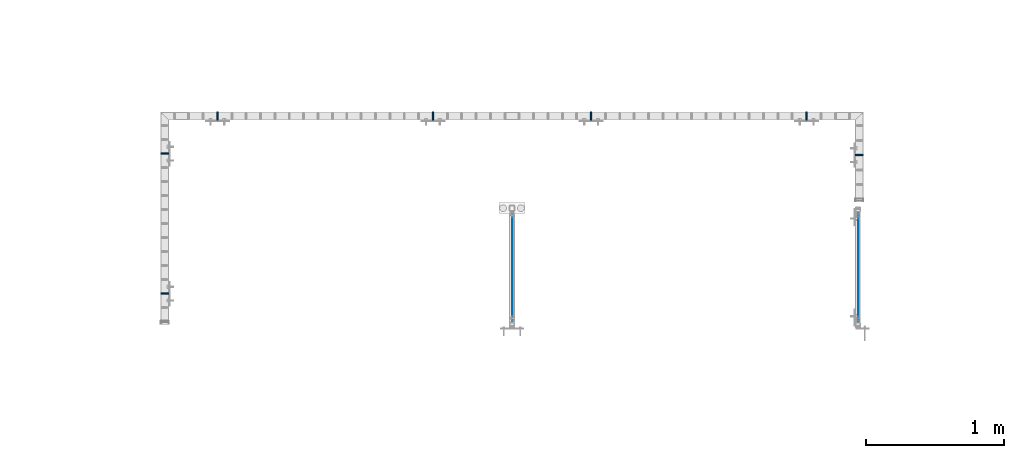
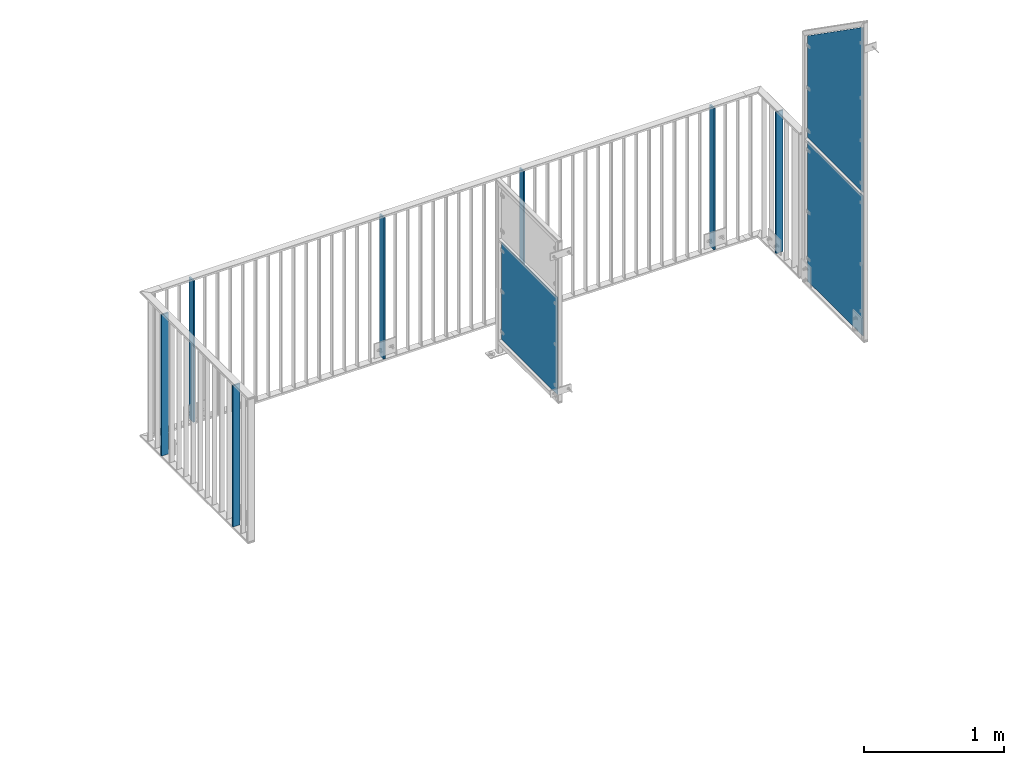
# One storey, part 48 of 156: 10 plates, 7 elements without a shape of their own.
"""IFC2X3 building model written with IfcOpenShell, lengths in millimetres."""

from ifc_helpers import new_model, si_unit, frame, origin_with_axes, origin_2d_with_axis, place, context, subcontext, project, spatial, rectangle, extrude, clip, halfspace, material, type_object, element, aggregate, save


model = new_model("IFC2X3")

# Units and contexts
model_context = context("Model", 3, precision=1e-05, world=origin_with_axes())
body_context = subcontext(model_context, "Body", "Model", "MODEL_VIEW")
ifc_project = project(units=[si_unit("LENGTHUNIT", "METRE", prefix="MILLI"), si_unit("AREAUNIT", "SQUARE_METRE"), si_unit("VOLUMEUNIT", "CUBIC_METRE"), si_unit("MASSUNIT", "GRAM", prefix="KILO"), si_unit("TIMEUNIT", "SECOND"), si_unit("PLANEANGLEUNIT", "RADIAN"), si_unit("SOLIDANGLEUNIT", "STERADIAN"), si_unit("THERMODYNAMICTEMPERATUREUNIT", "DEGREE_CELSIUS"), si_unit("LUMINOUSINTENSITYUNIT", "LUMEN")], contexts=[model_context])

# Site, building, storey
site_placement = place(None, origin_with_axes())
site = spatial("IfcSite", under=ifc_project, at=site_placement, CompositionType="ELEMENT")
building_placement = place(site_placement, origin_with_axes())
building = spatial("IfcBuilding", under=site, at=building_placement, Name="Undefined", CompositionType="ELEMENT")
storey_placement = place(building_placement, origin_with_axes())
storey = spatial("IfcBuildingStorey", under=building, at=storey_placement, Name="Undefined", CompositionType="ELEMENT", Elevation=0.0)

# Assembly, plate
assembly_1_placement = place(storey_placement, origin_with_axes())
assembly_1 = element("IfcElementAssembly", 1, at=assembly_1_placement, inside=storey, AssemblyPlace="NOTDEFINED", PredefinedType="RIGID_FRAME")
ifc_material = material(Name="STEEL/S235JR")
plate_type_1 = type_object("IfcPlateType", PredefinedType="NOTDEFINED")
plate_1_placement = place(assembly_1_placement, frame((41074.9973674284, 20366.5798484974, 3980.00000000003), z_axis=(1.0, 0.0, 0.0), x_axis=(0.0, 0.0, -1.0)))
plate_1 = element("IfcPlate", 2, at=plate_1_placement, type_object=plate_type_1, material=ifc_material, context=body_context, shape_type="SweptSolid", body=[
    extrude(rectangle(XDim=12.0, YDim=60.0, at=origin_2d_with_axis()), frame((1230.0, 0.0, 0.0), z_axis=(-1.0, 0.0, 0.0), x_axis=(0.0, -1.0, 0.0)), (0.0, 0.0, 1.0), 1230.0),
])

assembly_2_placement = place(storey_placement, origin_with_axes())
assembly_2 = element("IfcElementAssembly", 3, at=assembly_2_placement, inside=storey, AssemblyPlace="NOTDEFINED", PredefinedType="RIGID_FRAME")
plate_2_placement = place(assembly_2_placement, frame((44174.6444496975, 21657.9904407992, 3980.00000000003), z_axis=(0.0, -1.0, 0.0), x_axis=(0.0, 0.0, -1.0)))
plate_2 = element("IfcPlate", 4, at=plate_2_placement, type_object=plate_type_1, material=ifc_material, context=body_context, shape_type="SweptSolid", body=[
    extrude(rectangle(XDim=12.0, YDim=60.0, at=origin_2d_with_axis()), frame((1230.0, 0.0, 0.0), z_axis=(-1.0, 0.0, 0.0), x_axis=(0.0, -1.0, 0.0)), (0.0, 0.0, 1.0), 1230.0),
])

# Assembly, plates
assembly_3_placement = place(storey_placement, origin_with_axes())
assembly_3 = element("IfcElementAssembly", 5, at=assembly_3_placement, inside=storey, AssemblyPlace="NOTDEFINED", PredefinedType="RIGID_FRAME")
plate_3_placement = place(assembly_3_placement, frame((43025.3391913759, 21657.9904407992, 3980.00000000003), z_axis=(0.0, -1.0, 0.0), x_axis=(0.0, 0.0, -1.0)))
plate_3 = element("IfcPlate", 6, at=plate_3_placement, type_object=plate_type_1, material=ifc_material, context=body_context, shape_type="SweptSolid", body=[
    extrude(rectangle(XDim=12.0, YDim=60.0, at=origin_2d_with_axis()), frame((1230.0, 0.0, 0.0), z_axis=(-1.0, 0.0, 0.0), x_axis=(0.0, -1.0, 0.0)), (0.0, 0.0, 1.0), 1230.0),
])
plate_4_placement = place(assembly_3_placement, frame((41458.3177394665, 21657.9904407992, 3980.00000000003), z_axis=(0.0, -1.0, 0.0), x_axis=(0.0, 0.0, -1.0)))
plate_4 = element("IfcPlate", 7, at=plate_4_placement, type_object=plate_type_1, material=ifc_material, context=body_context, shape_type="SweptSolid", body=[
    extrude(rectangle(XDim=12.0, YDim=60.0, at=origin_2d_with_axis()), frame((1230.0, 0.0, 0.0), z_axis=(-1.0, 0.0, 0.0), x_axis=(0.0, -1.0, 0.0)), (0.0, 0.0, 1.0), 1230.0),
])
aggregate(assembly_3, [plate_3, plate_4])

# Assembly, plate
assembly_4_placement = place(storey_placement, origin_with_axes())
assembly_4 = element("IfcElementAssembly", 8, at=assembly_4_placement, inside=storey, AssemblyPlace="NOTDEFINED", PredefinedType="RIGID_FRAME")
plate_5_placement = place(assembly_4_placement, frame((46124.9972919954, 21374.1492182574, 3980.00000000003), z_axis=(-1.0, 0.0, 0.0), x_axis=(0.0, 0.0, -1.0)))
plate_5 = element("IfcPlate", 9, at=plate_5_placement, type_object=plate_type_1, material=ifc_material, context=body_context, shape_type="SweptSolid", body=[
    extrude(rectangle(XDim=12.0, YDim=60.0, at=origin_2d_with_axis()), frame((1230.0, 0.0, 0.0), z_axis=(-1.0, 0.0, 0.0), x_axis=(0.0, -1.0, 0.0)), (0.0, 0.0, 1.0), 1230.0),
])
aggregate(assembly_4, [plate_5])

# Plate
plate_6_placement = place(assembly_2_placement, frame((45741.665901607, 21657.9904407992, 3980.00000000003), z_axis=(0.0, -1.0, 0.0), x_axis=(0.0, 0.0, -1.0)))
plate_6 = element("IfcPlate", 10, at=plate_6_placement, type_object=plate_type_1, material=ifc_material, context=body_context, shape_type="SweptSolid", body=[
    extrude(rectangle(XDim=12.0, YDim=60.0, at=origin_2d_with_axis()), frame((1230.0, 0.0, 0.0), z_axis=(-1.0, 0.0, 0.0), x_axis=(0.0, -1.0, 0.0)), (0.0, 0.0, 1.0), 1230.0),
])

aggregate(assembly_2, [plate_2, plate_6])

plate_7_placement = place(assembly_1_placement, frame((41074.9973674284, 21384.4292182574, 3980.00000000003), z_axis=(1.0, 0.0, 0.0), x_axis=(0.0, 0.0, -1.0)))
plate_7 = element("IfcPlate", 11, at=plate_7_placement, type_object=plate_type_1, material=ifc_material, context=body_context, shape_type="SweptSolid", body=[
    extrude(rectangle(XDim=12.0, YDim=60.0, at=origin_2d_with_axis()), frame((1230.0, 0.0, 0.0), z_axis=(-1.0, 0.0, 0.0), x_axis=(0.0, -1.0, 0.0)), (0.0, 0.0, 1.0), 1230.0),
])

aggregate(assembly_1, [plate_1, plate_7])

# Assembly, plate
assembly_5_placement = place(storey_placement, origin_with_axes())
assembly_5 = element("IfcElementAssembly", 12, at=assembly_5_placement, inside=storey, AssemblyPlace="NOTDEFINED", PredefinedType="RIGID_FRAME")
plate_type_2 = type_object("IfcPlateType", PredefinedType="NOTDEFINED")
plate_8_placement = place(assembly_5_placement, frame((43603.9990081787, 20162.9547923074, 3550.0), z_axis=(0.0, 0.0, 1.0), x_axis=(0.0, 1.0, 0.0)))
plate_8 = element("IfcPlate", 13, at=plate_8_placement, type_object=plate_type_2, material=ifc_material, context=body_context, shape_type="SweptSolid", body=[
    extrude(rectangle(XDim=3.0, YDim=850.0, at=origin_2d_with_axis()), frame((800.050991195178, 0.0, 0.0), z_axis=(-1.0, 0.0, 0.0), x_axis=(0.0, -1.0, 0.0)), (0.0, 0.0, 1.0), 800.05),
])
aggregate(assembly_5, [plate_8])

assembly_6_placement = place(storey_placement, origin_with_axes())
assembly_6 = element("IfcElementAssembly", 14, at=assembly_6_placement, inside=storey, AssemblyPlace="NOTDEFINED", PredefinedType="RIGID_FRAME")
plate_type_3 = type_object("IfcPlateType", PredefinedType="NOTDEFINED")
plate_9_placement = place(assembly_6_placement, frame((46118.9951324463, 20163.0091093971, 3365.0), z_axis=(0.0, 0.0, 1.0), x_axis=(0.0, 1.0, 0.0)))
plate_9 = element("IfcPlate", 15, at=plate_9_placement, type_object=plate_type_3, material=ifc_material, context=body_context, shape_type="SweptSolid", body=[
    extrude(rectangle(XDim=3.0, YDim=1220.0, at=origin_2d_with_axis()), frame((790.000991195178, 0.0, 0.0), z_axis=(-1.0, 0.0, 0.0), x_axis=(0.0, -1.0, 0.0)), (0.0, 0.0, 1.0), 790.0),
])
aggregate(assembly_6, [plate_9])

assembly_7_placement = place(storey_placement, origin_with_axes())
assembly_7 = element("IfcElementAssembly", 16, at=assembly_7_placement, inside=storey, AssemblyPlace="NOTDEFINED", PredefinedType="RIGID_FRAME")
plate_10_placement = place(assembly_7_placement, frame((46118.9951324463, 20163.0021764144, 4730.00076289195), z_axis=(0.0, 0.0, 1.0), x_axis=(0.0, 1.0, 0.0)))
plate_10 = element("IfcPlate", 17, at=plate_10_placement, type_object=plate_type_3, material=ifc_material, context=body_context, shape_type="Clipping", body=[
    clip(extrude(rectangle(XDim=3.0, YDim=1450.0, at=origin_2d_with_axis()), frame((790.000991195178, 0.0, 0.0), z_axis=(-1.0, 0.0, 0.0), x_axis=(0.0, -1.0, 0.0)), (0.0, 0.0, 1.0), 790.0), halfspace(frame((2059.65165642691, -1.5, -729.1), z_axis=(0.573576519196191, 0.0, 0.819151986280191), x_axis=(-0.819151986280191, 0.0, 0.573576519196191)), False)),
])
aggregate(assembly_7, [plate_10])

save(model, "model.ifc")
